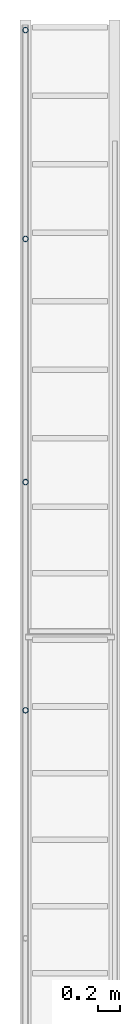
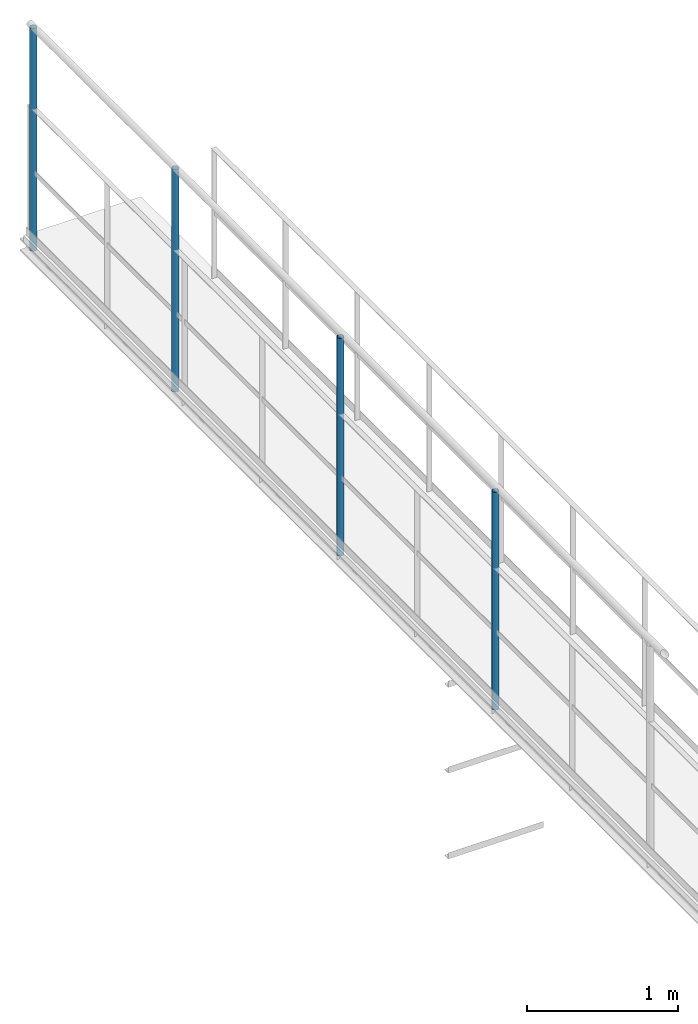
# One storey, part 3 of 6: 4 members.
"""IFC2X3 building model written with IfcOpenShell, lengths in metres."""

from ifc_helpers import new_model, entity, si_unit, converted_unit, derived_unit, direction, frame, frame_2d, origin, place, context, subcontext, project, spatial, hollow_circle, extrude, source, transform, mapped, material, type_object, type_shapes, element, save


model = new_model("IFC2X3")

# Units and contexts
model_context = context("Model", 3, precision=1e-05, world=origin(), true_north=direction((6.123233995736766e-17, 1.0)))
body_context = subcontext(model_context, "Body", "Model", "MODEL_VIEW")
ifc_project = project(units=[si_unit("LENGTHUNIT", "METRE"), converted_unit("PLANEANGLEUNIT", "DEGREE", entity("IfcPlaneAngleMeasure", 0.017453292519943278), si_unit("PLANEANGLEUNIT", "RADIAN"), dimensions=[0, 0, 0, 0, 0, 0, 0]), si_unit("AREAUNIT", "SQUARE_METRE"), derived_unit("THERMALTRANSMITTANCEUNIT", [(si_unit("MASSUNIT", "GRAM", prefix="KILO"), 1), (si_unit("THERMODYNAMICTEMPERATUREUNIT", "KELVIN"), -1), (si_unit("TIMEUNIT", "SECOND"), -3)])], contexts=[model_context])

# Site, building, storey
site_placement = place(None, origin())
site = spatial("IfcSite", under=ifc_project, at=site_placement, CompositionType="ELEMENT")
building_placement = place(site_placement, origin())
building = spatial("IfcBuilding", under=site, at=building_placement, CompositionType="ELEMENT")
storey_placement = place(building_placement, frame((0.0, 0.0, 8.8)))
storey = spatial("IfcBuildingStorey", under=building, at=storey_placement, Name="Piso 2.3", CompositionType="ELEMENT", Elevation=8.8)

# Members
ifc_material = material(Name="Metal - Steel - 345 MPa")
member_type_1 = type_object("IfcMemberType", Name="Circular Hollow Sections:TRON50x2.5", PredefinedType="BRACE", material=ifc_material)
shared_shape_1 = source(origin(), body_context, "Body", "SweptSolid", [
    extrude(hollow_circle(Radius=0.025000000000000813, WallThickness=0.0025000000000008106, at=frame_2d((-6.350472522025309e-19, -4.307027054717513e-17), x_axis=(1.0, 0.0))), frame((-0.9, 0.0, 0.0), z_axis=(1.0, 0.0, 0.0), x_axis=(0.0, 1.0, 0.0)), (0.0, 0.0, 1.0), 1.762),
])
type_shapes(member_type_1, [shared_shape_1])
for number, where, z_axis, x_axis, name in (
    (1, (3.706697135192132, 3.8486055151650795, 0.9), (0.0, -1.0, 0.0), (0.0, 0.0, 1.0), "Circular Hollow Sections:TRON50x2.5"),
    (2, (3.7066971351921354, 5.903834975103005, 0.9), (0.0, -1.0, 0.0), (0.0, 0.0, 1.0), "Circular Hollow Sections:TRON50x2.5"),
):
    element("IfcMember", number, at=place(storey_placement, frame(where, z_axis=z_axis, x_axis=x_axis)), inside=storey, type_object=member_type_1, material=ifc_material, Name=name, ObjectType="Circular Hollow Sections:TRON50x2.5", context=body_context, shape_type="MappedRepresentation", body=[
        mapped(shared_shape_1, transform((0.0, 0.0, 0.0), scale=1.0)),
    ])
member_type_2 = type_object("IfcMemberType", Name="Circular Hollow Sections:TRON50x2.5", PredefinedType="BRACE", material=ifc_material)
shared_shape_2 = source(origin(), body_context, "Body", "SweptSolid", [
    extrude(hollow_circle(Radius=0.025000000000000813, WallThickness=0.0025000000000008106, at=frame_2d((-3.464524456159266e-17, -6.350472522026428e-19), x_axis=(1.0, 0.0))), frame((-0.9, 0.0, 0.0), z_axis=(1.0, 0.0, 0.0), x_axis=(0.0, 0.0, -1.0)), (0.0, 0.0, 1.0), 1.8),
])
type_shapes(member_type_2, [shared_shape_2])
for number, where, z_axis, x_axis, name in (
    (3, (3.7066971351921487, 8.093834975102999, 0.9000000000000022), (0.0, 1.0, 0.0), (0.0, 0.0, 1.0), "Circular Hollow Sections:TRON50x2.5"),
    (4, (3.7066971351921527, 9.973834975103001, 0.9000000000000087), (0.0, 1.0, 0.0), (0.0, 0.0, 1.0), "Circular Hollow Sections:TRON50x2.5"),
):
    element("IfcMember", number, at=place(storey_placement, frame(where, z_axis=z_axis, x_axis=x_axis)), inside=storey, type_object=member_type_2, material=ifc_material, Name=name, ObjectType="Circular Hollow Sections:TRON50x2.5", context=body_context, shape_type="MappedRepresentation", body=[
        mapped(shared_shape_2, transform((0.0, 0.0, 0.0), scale=1.0)),
    ])

save(model, "model.ifc")
